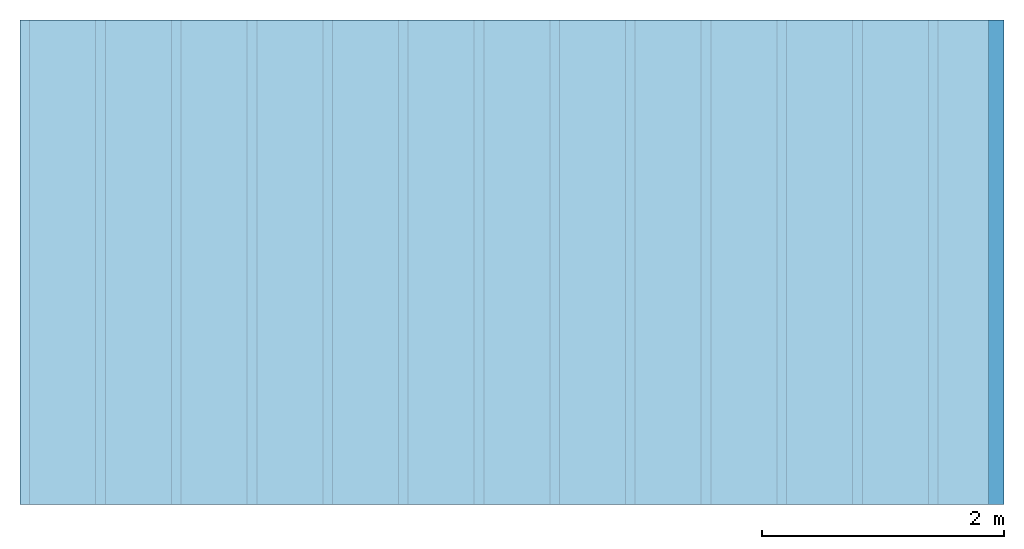
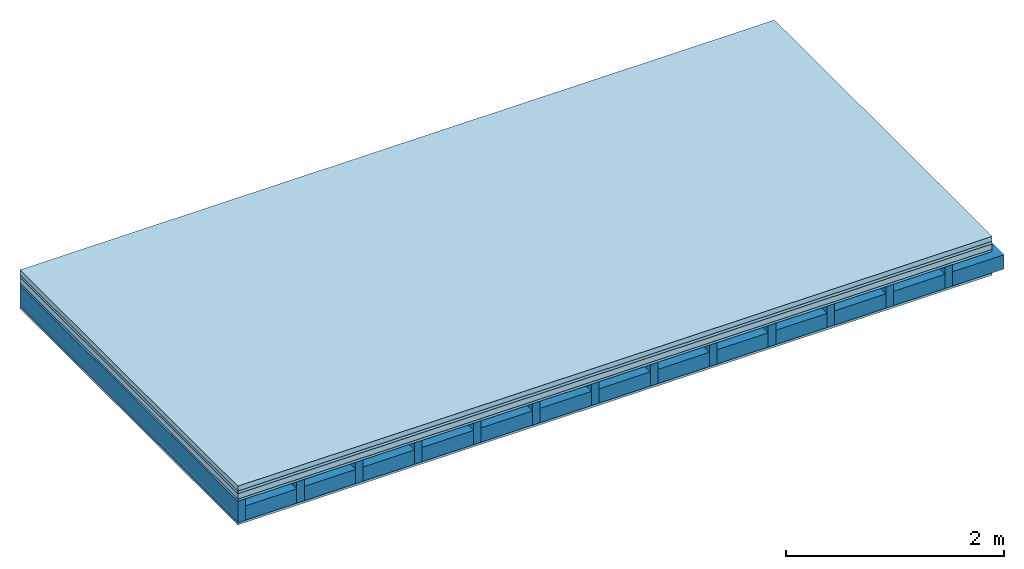
# One storey: 5 plates, 2 members, 1 element without a shape of its own.
"""IFC4 building model written with IfcOpenShell, lengths in metres."""

from ifc_helpers import new_model, si_unit, derived_unit, direction, frame, frame_2d, origin, origin_with_axes, place, context, project, spatial, rectangle, extrude, material, layer, layer_set, type_object, element, aggregate, save


model = new_model("IFC4")

# Units and contexts
plan_context = context("Plan", 3, precision=1e-05, world=origin(), true_north=direction((0.0, 1.0)))
model_context = context("Model", 3, precision=1e-05, world=origin(), true_north=direction((0.0, 1.0)))
ifc_project = project(units=[si_unit("LENGTHUNIT", "METRE"), derived_unit("SOUNDPRESSUREUNIT", [(si_unit("PRESSUREUNIT", "PASCAL", prefix="MICRO"), 0)]), si_unit("ENERGYUNIT", "JOULE", prefix="MEGA"), si_unit("MASSUNIT", "GRAM", prefix="KILO"), derived_unit("THERMALTRANSMITTANCEUNIT", [(si_unit("POWERUNIT", "WATT"), 1), (si_unit("AREAUNIT", "SQUARE_METRE"), -1), (si_unit("THERMODYNAMICTEMPERATUREUNIT", "KELVIN"), -1)]), derived_unit("AREADENSITYUNIT", [(si_unit("MASSUNIT", "GRAM", prefix="KILO"), 1), (si_unit("AREAUNIT", "SQUARE_METRE"), -1)]), derived_unit("USERDEFINED", [(si_unit("ENERGYUNIT", "JOULE", prefix="MEGA"), 1), (si_unit("AREAUNIT", "SQUARE_METRE"), -1)])], contexts=[plan_context, model_context])

# Site, building, storey
site = spatial("IfcSite", under=ifc_project)
building_placement = place(None, origin())
building = spatial("IfcBuilding", under=site, at=building_placement)
storey_placement = place(building_placement, origin())
storey = spatial("IfcBuildingStorey", under=building, at=storey_placement)

# Slab, members, plates
ifc_material_1 = material(Category="04.005")
ifc_layer_1 = layer(ifc_material_1, 0.055, Name="On-material")
ifc_material_2 = material()
ifc_layer_2 = layer(ifc_material_2, 0.03, Name="Impact sound insulation")
ifc_material_3 = material(Category="03.011")
ifc_layer_3 = layer(ifc_material_3, 0.06, Name="on Supporting structure")
ifc_material_4 = material(Category="07.001")
ifc_layer_4 = layer(ifc_material_4, 0.025, Name="Sub-floor")
ifc_material_5 = material(Name="Rigid, of the art")
ifc_layer_5 = layer(ifc_material_5, 0.0, Name="Bond")
ifc_layer_6 = layer(None, 0.24, Name="Supporting structure")
ifc_layer_7 = layer(ifc_material_5, 0.0, Name="Bond")
ifc_layer_8 = layer(ifc_material_4, 0.025, Name="Lower layer 1")
ifc_layer_set = layer_set([ifc_layer_1, ifc_layer_2, ifc_layer_3, ifc_layer_4, ifc_layer_5, ifc_layer_6, ifc_layer_7, ifc_layer_8])
slab_type = type_object("IfcSlabType", Name="A0440", PredefinedType="NOTDEFINED", material=ifc_layer_set)
slab_placement = place(None, frame((0.0, 0.0, 0.0), z_axis=(0.0, 0.0, -1.0), x_axis=(1.0, 0.0, 0.0)))
slab = element("IfcSlab", 1, at=slab_placement, inside=storey, type_object=slab_type, material=ifc_layer_set, Name="Slab #1")
ifc_material_6 = material()
member_1_placement = place(slab_placement, origin())
member_1 = element("IfcMember", 2, at=member_1_placement, material=ifc_material_6, Name="Supporting structure", context=plan_context, shape_type="SweptSolid", body=[
    extrude(rectangle(XDim=0.08, YDim=0.24, at=frame_2d((0.04, 0.12), x_axis=(1.0, 0.0))), frame((0.0, 4.0, 0.17), z_axis=(0.0, -1.0, 0.0), x_axis=(1.0, 0.0, 0.0)), (0.0, 0.0, 1.0), 4.0),
    extrude(rectangle(XDim=0.08, YDim=0.24, at=frame_2d((0.04, 0.12), x_axis=(1.0, 0.0))), frame((0.625, 4.0, 0.17), z_axis=(0.0, -1.0, 0.0), x_axis=(1.0, 0.0, 0.0)), (0.0, 0.0, 1.0), 4.0),
    extrude(rectangle(XDim=0.08, YDim=0.24, at=frame_2d((0.04, 0.12), x_axis=(1.0, 0.0))), frame((1.25, 4.0, 0.17), z_axis=(0.0, -1.0, 0.0), x_axis=(1.0, 0.0, 0.0)), (0.0, 0.0, 1.0), 4.0),
    extrude(rectangle(XDim=0.08, YDim=0.24, at=frame_2d((0.04, 0.12), x_axis=(1.0, 0.0))), frame((1.875, 4.0, 0.17), z_axis=(0.0, -1.0, 0.0), x_axis=(1.0, 0.0, 0.0)), (0.0, 0.0, 1.0), 4.0),
    extrude(rectangle(XDim=0.08, YDim=0.24, at=frame_2d((0.04, 0.12), x_axis=(1.0, 0.0))), frame((2.5, 4.0, 0.17), z_axis=(0.0, -1.0, 0.0), x_axis=(1.0, 0.0, 0.0)), (0.0, 0.0, 1.0), 4.0),
    extrude(rectangle(XDim=0.08, YDim=0.24, at=frame_2d((0.04, 0.12), x_axis=(1.0, 0.0))), frame((3.125, 4.0, 0.17), z_axis=(0.0, -1.0, 0.0), x_axis=(1.0, 0.0, 0.0)), (0.0, 0.0, 1.0), 4.0),
    extrude(rectangle(XDim=0.08, YDim=0.24, at=frame_2d((0.04, 0.12), x_axis=(1.0, 0.0))), frame((3.75, 4.0, 0.17), z_axis=(0.0, -1.0, 0.0), x_axis=(1.0, 0.0, 0.0)), (0.0, 0.0, 1.0), 4.0),
    extrude(rectangle(XDim=0.08, YDim=0.24, at=frame_2d((0.04, 0.12), x_axis=(1.0, 0.0))), frame((4.375, 4.0, 0.17), z_axis=(0.0, -1.0, 0.0), x_axis=(1.0, 0.0, 0.0)), (0.0, 0.0, 1.0), 4.0),
    extrude(rectangle(XDim=0.08, YDim=0.24, at=frame_2d((0.04, 0.12), x_axis=(1.0, 0.0))), frame((5.0, 4.0, 0.17), z_axis=(0.0, -1.0, 0.0), x_axis=(1.0, 0.0, 0.0)), (0.0, 0.0, 1.0), 4.0),
    extrude(rectangle(XDim=0.08, YDim=0.24, at=frame_2d((0.04, 0.12), x_axis=(1.0, 0.0))), frame((5.625, 4.0, 0.17), z_axis=(0.0, -1.0, 0.0), x_axis=(1.0, 0.0, 0.0)), (0.0, 0.0, 1.0), 4.0),
    extrude(rectangle(XDim=0.08, YDim=0.24, at=frame_2d((0.04, 0.12), x_axis=(1.0, 0.0))), frame((6.25, 4.0, 0.17), z_axis=(0.0, -1.0, 0.0), x_axis=(1.0, 0.0, 0.0)), (0.0, 0.0, 1.0), 4.0),
    extrude(rectangle(XDim=0.08, YDim=0.24, at=frame_2d((0.04, 0.12), x_axis=(1.0, 0.0))), frame((6.875, 4.0, 0.17), z_axis=(0.0, -1.0, 0.0), x_axis=(1.0, 0.0, 0.0)), (0.0, 0.0, 1.0), 4.0),
    extrude(rectangle(XDim=0.08, YDim=0.24, at=frame_2d((0.04, 0.12), x_axis=(1.0, 0.0))), frame((7.5, 4.0, 0.17), z_axis=(0.0, -1.0, 0.0), x_axis=(1.0, 0.0, 0.0)), (0.0, 0.0, 1.0), 4.0),
])
ifc_material_7 = material()
member_2_placement = place(slab_placement, origin())
member_2 = element("IfcMember", 3, at=member_2_placement, material=ifc_material_7, Name="Cavity", context=plan_context, shape_type="SweptSolid", body=[
    extrude(rectangle(XDim=0.545, YDim=0.16, at=frame_2d((0.2725, 0.08), x_axis=(1.0, 0.0))), frame((0.08, 4.0, 0.25), z_axis=(0.0, -1.0, 0.0), x_axis=(1.0, 0.0, 0.0)), (0.0, 0.0, 1.0), 4.0),
    extrude(rectangle(XDim=0.545, YDim=0.16, at=frame_2d((0.2725, 0.08), x_axis=(1.0, 0.0))), frame((0.705, 4.0, 0.25), z_axis=(0.0, -1.0, 0.0), x_axis=(1.0, 0.0, 0.0)), (0.0, 0.0, 1.0), 4.0),
    extrude(rectangle(XDim=0.545, YDim=0.16, at=frame_2d((0.2725, 0.08), x_axis=(1.0, 0.0))), frame((1.33, 4.0, 0.25), z_axis=(0.0, -1.0, 0.0), x_axis=(1.0, 0.0, 0.0)), (0.0, 0.0, 1.0), 4.0),
    extrude(rectangle(XDim=0.545, YDim=0.16, at=frame_2d((0.2725, 0.08), x_axis=(1.0, 0.0))), frame((1.955, 4.0, 0.25), z_axis=(0.0, -1.0, 0.0), x_axis=(1.0, 0.0, 0.0)), (0.0, 0.0, 1.0), 4.0),
    extrude(rectangle(XDim=0.545, YDim=0.16, at=frame_2d((0.2725, 0.08), x_axis=(1.0, 0.0))), frame((2.58, 4.0, 0.25), z_axis=(0.0, -1.0, 0.0), x_axis=(1.0, 0.0, 0.0)), (0.0, 0.0, 1.0), 4.0),
    extrude(rectangle(XDim=0.545, YDim=0.16, at=frame_2d((0.2725, 0.08), x_axis=(1.0, 0.0))), frame((3.205, 4.0, 0.25), z_axis=(0.0, -1.0, 0.0), x_axis=(1.0, 0.0, 0.0)), (0.0, 0.0, 1.0), 4.0),
    extrude(rectangle(XDim=0.545, YDim=0.16, at=frame_2d((0.2725, 0.08), x_axis=(1.0, 0.0))), frame((3.83, 4.0, 0.25), z_axis=(0.0, -1.0, 0.0), x_axis=(1.0, 0.0, 0.0)), (0.0, 0.0, 1.0), 4.0),
    extrude(rectangle(XDim=0.545, YDim=0.16, at=frame_2d((0.2725, 0.08), x_axis=(1.0, 0.0))), frame((4.455, 4.0, 0.25), z_axis=(0.0, -1.0, 0.0), x_axis=(1.0, 0.0, 0.0)), (0.0, 0.0, 1.0), 4.0),
    extrude(rectangle(XDim=0.545, YDim=0.16, at=frame_2d((0.2725, 0.08), x_axis=(1.0, 0.0))), frame((5.08, 4.0, 0.25), z_axis=(0.0, -1.0, 0.0), x_axis=(1.0, 0.0, 0.0)), (0.0, 0.0, 1.0), 4.0),
    extrude(rectangle(XDim=0.545, YDim=0.16, at=frame_2d((0.2725, 0.08), x_axis=(1.0, 0.0))), frame((5.705, 4.0, 0.25), z_axis=(0.0, -1.0, 0.0), x_axis=(1.0, 0.0, 0.0)), (0.0, 0.0, 1.0), 4.0),
    extrude(rectangle(XDim=0.545, YDim=0.16, at=frame_2d((0.2725, 0.08), x_axis=(1.0, 0.0))), frame((6.33, 4.0, 0.25), z_axis=(0.0, -1.0, 0.0), x_axis=(1.0, 0.0, 0.0)), (0.0, 0.0, 1.0), 4.0),
    extrude(rectangle(XDim=0.545, YDim=0.16, at=frame_2d((0.2725, 0.08), x_axis=(1.0, 0.0))), frame((6.955, 4.0, 0.25), z_axis=(0.0, -1.0, 0.0), x_axis=(1.0, 0.0, 0.0)), (0.0, 0.0, 1.0), 4.0),
    extrude(rectangle(XDim=0.545, YDim=0.16, at=frame_2d((0.2725, 0.08), x_axis=(1.0, 0.0))), frame((7.58, 4.0, 0.25), z_axis=(0.0, -1.0, 0.0), x_axis=(1.0, 0.0, 0.0)), (0.0, 0.0, 1.0), 4.0),
])
plate_1_placement = place(slab_placement, origin())
plate_1 = element("IfcPlate", 4, at=plate_1_placement, material=ifc_material_1, Name="On-material", context=plan_context, shape_type="SweptSolid", body=[
    extrude(rectangle(XDim=8.0, YDim=4.0, at=frame_2d((4.0, 2.0), x_axis=(1.0, 0.0))), origin_with_axes(), (0.0, 0.0, 1.0), 0.055),
])
plate_2_placement = place(slab_placement, origin())
plate_2 = element("IfcPlate", 5, at=plate_2_placement, material=ifc_material_2, Name="Impact sound insulation", context=plan_context, shape_type="SweptSolid", body=[
    extrude(rectangle(XDim=8.0, YDim=4.0, at=frame_2d((4.0, 2.0), x_axis=(1.0, 0.0))), frame((0.0, 0.0, 0.055), z_axis=(0.0, 0.0, 1.0), x_axis=(1.0, 0.0, 0.0)), (0.0, 0.0, 1.0), 0.03),
])
plate_3_placement = place(slab_placement, origin())
plate_3 = element("IfcPlate", 6, at=plate_3_placement, material=ifc_material_3, Name="on Supporting structure", context=plan_context, shape_type="SweptSolid", body=[
    extrude(rectangle(XDim=8.0, YDim=4.0, at=frame_2d((4.0, 2.0), x_axis=(1.0, 0.0))), frame((0.0, 0.0, 0.085), z_axis=(0.0, 0.0, 1.0), x_axis=(1.0, 0.0, 0.0)), (0.0, 0.0, 1.0), 0.06),
])
plate_4_placement = place(slab_placement, origin())
plate_4 = element("IfcPlate", 7, at=plate_4_placement, material=ifc_material_4, Name="Sub-floor", context=plan_context, shape_type="SweptSolid", body=[
    extrude(rectangle(XDim=8.0, YDim=4.0, at=frame_2d((4.0, 2.0), x_axis=(1.0, 0.0))), frame((0.0, 0.0, 0.145), z_axis=(0.0, 0.0, 1.0), x_axis=(1.0, 0.0, 0.0)), (0.0, 0.0, 1.0), 0.025),
])
plate_5_placement = place(slab_placement, origin())
plate_5 = element("IfcPlate", 8, at=plate_5_placement, material=ifc_material_4, Name="Lower layer 1", context=plan_context, shape_type="SweptSolid", body=[
    extrude(rectangle(XDim=8.0, YDim=4.0, at=frame_2d((4.0, 2.0), x_axis=(1.0, 0.0))), frame((0.0, 0.0, 0.41), z_axis=(0.0, 0.0, 1.0), x_axis=(1.0, 0.0, 0.0)), (0.0, 0.0, 1.0), 0.025),
])
aggregate(slab, [plate_1, plate_2, plate_3, plate_4, member_1, member_2, plate_5])

save(model, "model.ifc")
